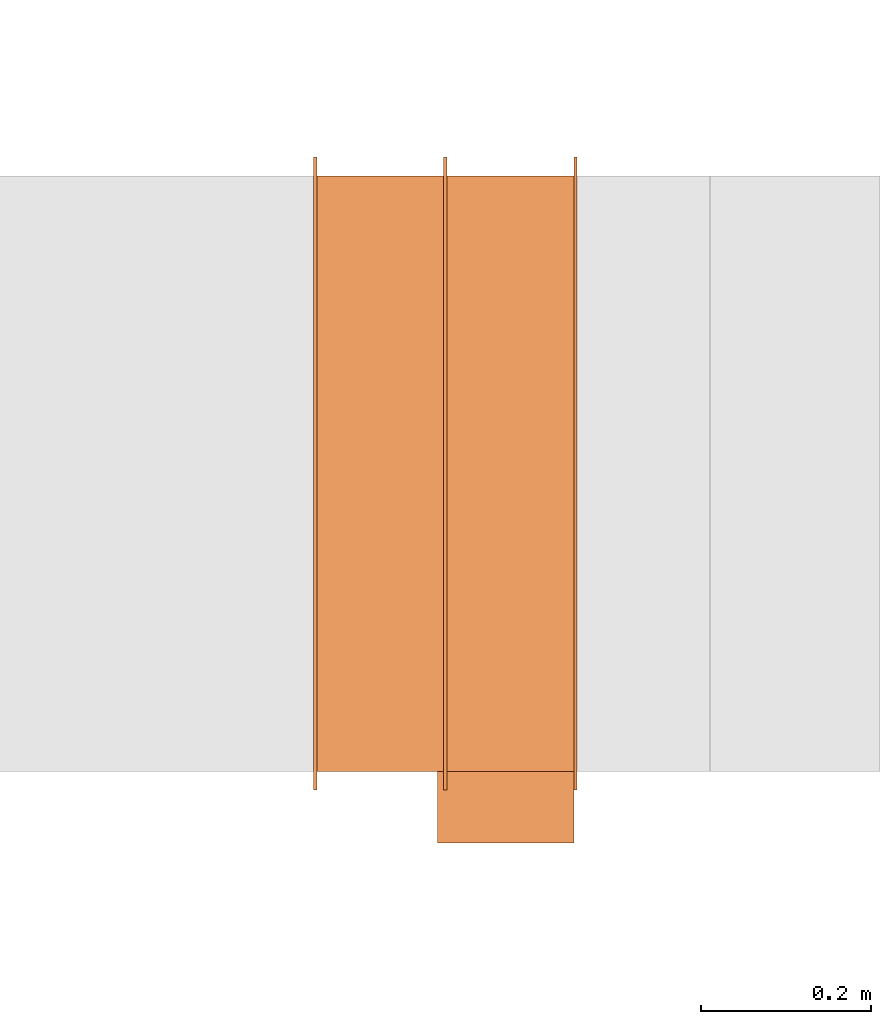
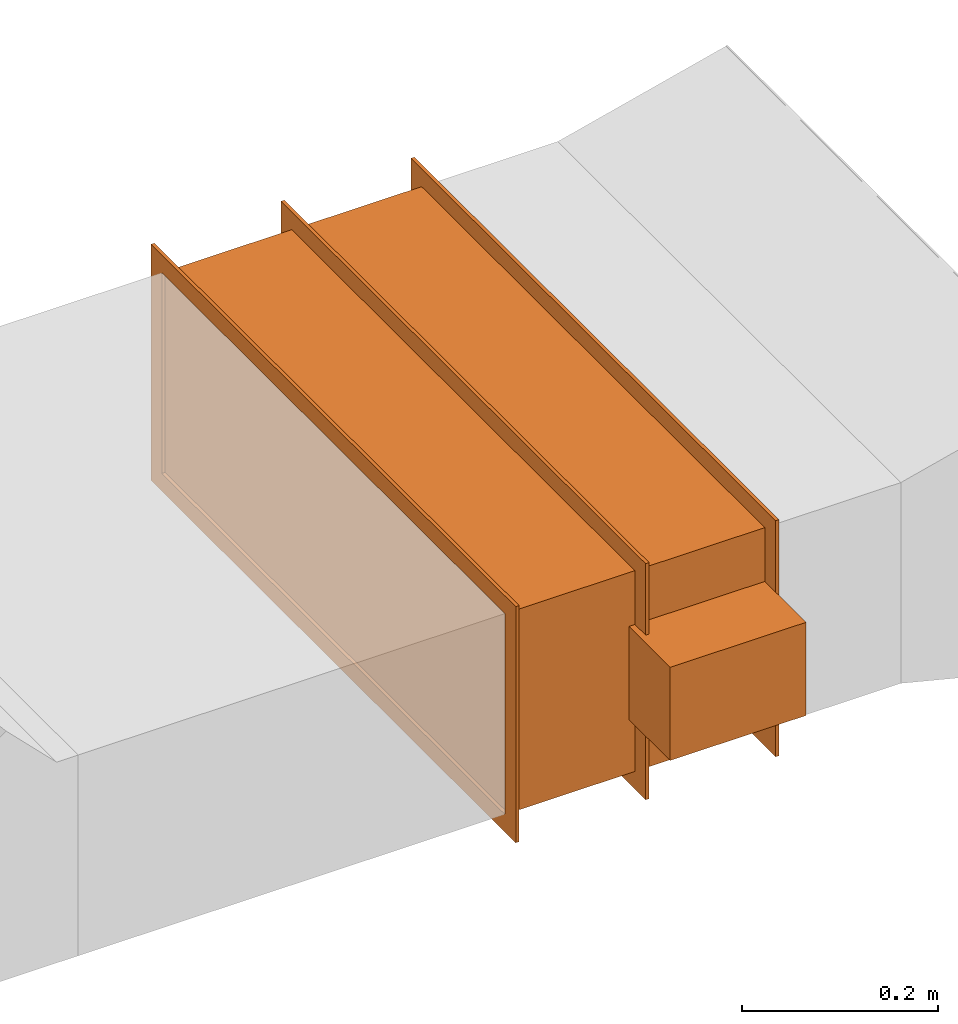
# One storey, part 2 of 2: 1 proxy.
"""IFC2X3 building model written with IfcOpenShell, lengths in millimetres."""

from ifc_helpers import new_model, entity, si_unit, converted_unit, derived_unit, direction, frame, origin, origin_2d_with_axis, place, context, subcontext, project, spatial, polyline, rectangle, outline, extrude, source, transform, mapped, type_object, type_shapes, element, save


model = new_model("IFC2X3")

# Units and contexts
model_context = context("Model", 3, precision=0.01, world=origin(), true_north=direction((6.12303176911189e-17, 1.0)))
body_context = subcontext(model_context, "Body", "Model", "MODEL_VIEW")
ifc_project = project(units=[si_unit("LENGTHUNIT", "METRE", prefix="MILLI"), si_unit("AREAUNIT", "SQUARE_METRE"), si_unit("VOLUMEUNIT", "CUBIC_METRE"), converted_unit("PLANEANGLEUNIT", "DEGREE", entity("IfcRatioMeasure", 0.0174532925199433), si_unit("PLANEANGLEUNIT", "RADIAN"), dimensions=[0, 0, 0, 0, 0, 0, 0]), si_unit("MASSUNIT", "GRAM", prefix="KILO"), derived_unit("MASSDENSITYUNIT", [(si_unit("MASSUNIT", "GRAM", prefix="KILO"), 1), (si_unit("LENGTHUNIT", "METRE"), -3)]), si_unit("TIMEUNIT", "SECOND"), si_unit("FREQUENCYUNIT", "HERTZ"), si_unit("THERMODYNAMICTEMPERATUREUNIT", "DEGREE_CELSIUS"), derived_unit("THERMALTRANSMITTANCEUNIT", [(si_unit("MASSUNIT", "GRAM", prefix="KILO"), 1), (si_unit("THERMODYNAMICTEMPERATUREUNIT", "KELVIN"), -1), (si_unit("TIMEUNIT", "SECOND"), -3)]), derived_unit("VOLUMETRICFLOWRATEUNIT", [(si_unit("LENGTHUNIT", "METRE"), 3), (si_unit("TIMEUNIT", "SECOND"), -1)]), si_unit("ELECTRICCURRENTUNIT", "AMPERE"), si_unit("ELECTRICVOLTAGEUNIT", "VOLT"), si_unit("POWERUNIT", "WATT"), si_unit("FORCEUNIT", "NEWTON", prefix="KILO"), si_unit("ILLUMINANCEUNIT", "LUX"), si_unit("LUMINOUSFLUXUNIT", "LUMEN"), si_unit("LUMINOUSINTENSITYUNIT", "CANDELA"), derived_unit("USERDEFINED", [(si_unit("MASSUNIT", "GRAM", prefix="KILO"), -1), (si_unit("LENGTHUNIT", "METRE"), -2), (si_unit("TIMEUNIT", "SECOND"), 3), (si_unit("LUMINOUSFLUXUNIT", "LUMEN"), 1)]), derived_unit("LINEARVELOCITYUNIT", [(si_unit("LENGTHUNIT", "METRE"), 1), (si_unit("TIMEUNIT", "SECOND"), -1)]), si_unit("PRESSUREUNIT", "PASCAL"), derived_unit("USERDEFINED", [(si_unit("LENGTHUNIT", "METRE"), -2), (si_unit("MASSUNIT", "GRAM", prefix="KILO"), 1), (si_unit("TIMEUNIT", "SECOND"), -2)])], contexts=[model_context])

# Site, building, storey
site_placement = place(None, origin())
site = spatial("IfcSite", under=ifc_project, at=site_placement, CompositionType="ELEMENT")
building_placement = place(site_placement, origin())
building = spatial("IfcBuilding", under=site, at=building_placement, CompositionType="ELEMENT")
storey_placement = place(building_placement, frame((0.0, 0.0, 16000.0)))
storey = spatial("IfcBuildingStorey", under=building, at=storey_placement, Name="04 Roof", CompositionType="ELEMENT", Elevation=16000.0)

# Proxy
building_element_proxy_type = type_object("IfcBuildingElementProxyType", Name="WK", PredefinedType="NOTDEFINED")
shared_shape = source(origin(), body_context, "Body", "SweptSolid", [
    extrude(outline(polyline([(-147.0, -372.0), (147.0, -372.0), (147.0, 372.0), (-147.0, 372.0), (-147.0, -372.0)]), holes=[polyline([(-125.0, -350.0), (-125.0, 350.0), (125.0, 350.0), (125.0, -350.0), (-125.0, -350.0)])]), frame((151.0, 0.0, 0.0), z_axis=(1.0, 0.0, 0.0), x_axis=(0.0, 0.0, -1.0)), (0.0, 0.0, 1.0), 4.0),
    extrude(outline(polyline([(-372.0, -147.0), (372.0, -147.0), (372.0, 147.0), (-372.0, 147.0), (-372.0, -147.0)]), holes=[polyline([(-350.0, -125.0), (-350.0, 125.0), (350.0, 125.0), (350.0, -125.0), (-350.0, -125.0)])]), frame((-155.0, 0.0, 0.0), z_axis=(1.0, 0.0, 0.0), x_axis=(0.0, -1.0, 0.0)), (0.0, 0.0, 1.0), 4.0),
    extrude(outline(polyline([(-372.0, -147.0), (372.0, -147.0), (372.0, 147.0), (-372.0, 147.0), (-372.0, -147.0)]), holes=[polyline([(-350.0, -125.0), (-350.0, 125.0), (350.0, 125.0), (350.0, -125.0), (-350.0, -125.0)])]), frame((-2.0, 0.0, 0.0), z_axis=(1.0, 0.0, 0.0), x_axis=(0.0, -1.0, 0.0)), (0.0, 0.0, 1.0), 4.0),
    extrude(rectangle(XDim=302.0, YDim=700.0, at=origin_2d_with_axis()), frame((0.0, 0.0, -125.0), z_axis=(0.0, 0.0, 1.0), x_axis=(-1.0, 0.0, 0.0)), (0.0, 0.0, 1.0), 250.0),
    extrude(rectangle(XDim=84.0, YDim=160.0, at=origin_2d_with_axis()), frame((71.0, -392.0, -58.0), z_axis=(0.0, 0.0, 1.0), x_axis=(0.0, -1.0, 0.0)), (0.0, 0.0, 1.0), 116.0),
])
type_shapes(building_element_proxy_type, [shared_shape])
proxy_placement = place(storey_placement, frame((28172.0457231092, -68831.2395851399, 1335.95052634352)))
element("IfcBuildingElementProxy", 1, at=proxy_placement, inside=storey, type_object=building_element_proxy_type, Name="WK25-0001:WK", ObjectType="WK25-0001:WK", context=body_context, shape_type="MappedRepresentation", body=[
    mapped(shared_shape, transform((0.0, 0.0, 0.0), scale=1.0)),
])

save(model, "model.ifc")
